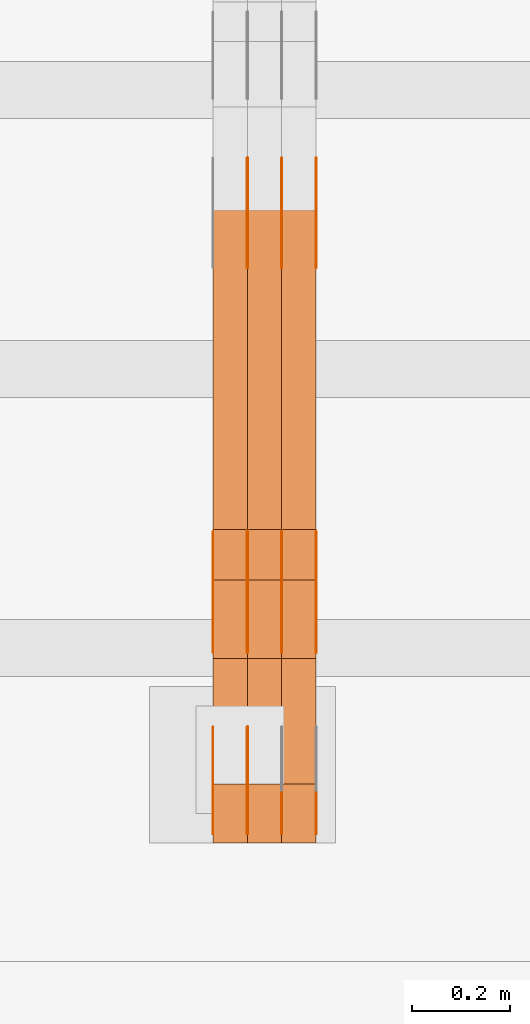
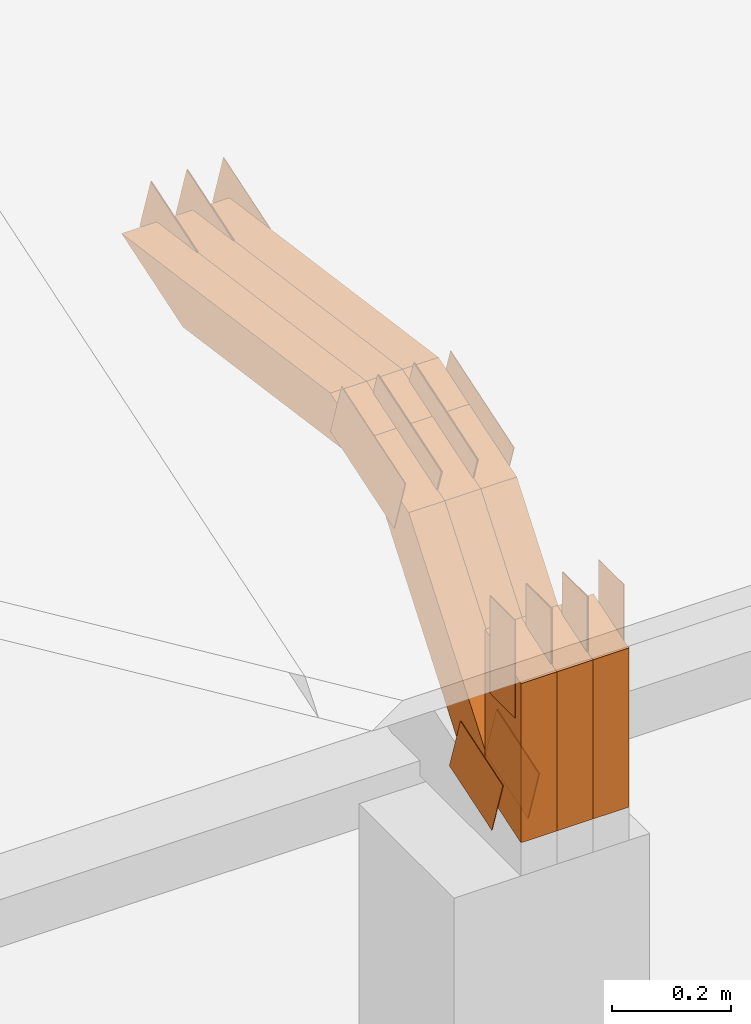
# One storey, part 248 of 385: 29 proxies.
"""IFC2X3 building model written with IfcOpenShell, lengths in millimetres."""

from ifc_helpers import new_model, entity, si_unit, converted_unit, derived_unit, direction, frame, frame_2d, origin, place, context, subcontext, project, spatial, polyline, rectangle, outline, extrude, source, transform, mapped, material, type_object, type_shapes, element, save


model = new_model("IFC2X3")

# Units and contexts
model_context = context("Model", 3, precision=0.01, world=origin(), true_north=direction((6.12303176911189e-17, 1.0)))
body_context = subcontext(model_context, "Body", "Model", "MODEL_VIEW")
ifc_project = project(units=[si_unit("LENGTHUNIT", "METRE", prefix="MILLI"), si_unit("AREAUNIT", "SQUARE_METRE"), si_unit("VOLUMEUNIT", "CUBIC_METRE"), converted_unit("PLANEANGLEUNIT", "DEGREE", entity("IfcRatioMeasure", 0.0174532925199433), si_unit("PLANEANGLEUNIT", "RADIAN"), dimensions=[0, 0, 0, 0, 0, 0, 0]), si_unit("MASSUNIT", "GRAM", prefix="KILO"), derived_unit("MASSDENSITYUNIT", [(si_unit("MASSUNIT", "GRAM", prefix="KILO"), 1), (si_unit("LENGTHUNIT", "METRE"), -3)]), si_unit("TIMEUNIT", "SECOND"), si_unit("FREQUENCYUNIT", "HERTZ"), si_unit("THERMODYNAMICTEMPERATUREUNIT", "DEGREE_CELSIUS"), derived_unit("THERMALTRANSMITTANCEUNIT", [(si_unit("MASSUNIT", "GRAM", prefix="KILO"), 1), (si_unit("THERMODYNAMICTEMPERATUREUNIT", "KELVIN"), -1), (si_unit("TIMEUNIT", "SECOND"), -3)]), derived_unit("VOLUMETRICFLOWRATEUNIT", [(si_unit("LENGTHUNIT", "METRE"), 3), (si_unit("TIMEUNIT", "SECOND"), -1)]), si_unit("ELECTRICCURRENTUNIT", "AMPERE"), si_unit("ELECTRICVOLTAGEUNIT", "VOLT"), si_unit("POWERUNIT", "WATT"), si_unit("FORCEUNIT", "NEWTON", prefix="KILO"), si_unit("ILLUMINANCEUNIT", "LUX"), si_unit("LUMINOUSFLUXUNIT", "LUMEN"), si_unit("LUMINOUSINTENSITYUNIT", "CANDELA"), derived_unit("USERDEFINED", [(si_unit("MASSUNIT", "GRAM", prefix="KILO"), -1), (si_unit("LENGTHUNIT", "METRE"), -2), (si_unit("TIMEUNIT", "SECOND"), 3), (si_unit("LUMINOUSFLUXUNIT", "LUMEN"), 1)]), derived_unit("LINEARVELOCITYUNIT", [(si_unit("LENGTHUNIT", "METRE"), 1), (si_unit("TIMEUNIT", "SECOND"), -1)]), si_unit("PRESSUREUNIT", "PASCAL"), derived_unit("USERDEFINED", [(si_unit("LENGTHUNIT", "METRE"), -2), (si_unit("MASSUNIT", "GRAM", prefix="KILO"), 1), (si_unit("TIMEUNIT", "SECOND"), -2)])], contexts=[model_context])

# Site, building, storey
site_placement = place(None, origin())
site = spatial("IfcSite", under=ifc_project, at=site_placement, CompositionType="ELEMENT")
building_placement = place(site_placement, origin())
building = spatial("IfcBuilding", under=site, at=building_placement, CompositionType="ELEMENT")
storey_placement = place(building_placement, origin())
storey = spatial("IfcBuildingStorey", under=building, at=storey_placement, Name="Default", CompositionType="ELEMENT", Elevation=0.0)

# Proxies
ifc_material_1 = material(Name="IfcSurfaceStyle #477585")
building_element_proxy_type_1 = type_object("IfcBuildingElementProxyType", PredefinedType="NOTDEFINED", material=ifc_material_1)
shared_shape_1 = source(origin(), body_context, "Body", "SweptSolid", [
    extrude(outline(polyline([(-74.999865408764, -60.0000379172698), (74.9998729365771, -60.0000379172698), (74.9998642299588, 60.0000379172698), (-74.9998717577719, 60.0000379172698), (-74.999865408764, -60.0000379172698)])), frame((75.0005044383734, 60.0001679035349, 0.0), z_axis=(0.0, 0.0, 1.0), x_axis=(-1.0, 0.0, 0.0)), (0.0, 0.0, 1.0), 1.29999999999999),
])
type_shapes(building_element_proxy_type_1, [shared_shape_1])
proxy_1_placement = place(building_placement, frame((39245.0, 2998.66143710398, 150.423871180894), z_axis=(-1.0, 0.0, 0.0), x_axis=(0.0, 0.951056516295124, 0.309016994375039)))
element("IfcBuildingElementProxy", 1, at=proxy_1_placement, inside=storey, type_object=building_element_proxy_type_1, material=ifc_material_1, context=body_context, shape_type="MappedRepresentation", body=[
    mapped(shared_shape_1, transform((0.0, 0.0, 0.0), scale=1.0)),
])
ifc_material_2 = material(Name="IfcSurfaceStyle #477528")
building_element_proxy_type_2 = type_object("IfcBuildingElementProxyType", PredefinedType="NOTDEFINED", material=ifc_material_2)
shared_shape_2 = source(origin(), body_context, "Body", "SweptSolid", [
    extrude(outline(polyline([(-74.999865408764, -60.0000379172698), (74.9998729365771, -60.0000379172698), (74.9998642299588, 60.0000379172698), (-74.9998717577719, 60.0000379172698), (-74.999865408764, -60.0000379172698)])), frame((75.0005044383734, 60.0001679035349, 0.0), z_axis=(0.0, 0.0, 1.0), x_axis=(-1.0, 0.0, 0.0)), (0.0, 0.0, 1.0), 1.29999999999999),
])
type_shapes(building_element_proxy_type_2, [shared_shape_2])
proxy_2_placement = place(building_placement, frame((39246.3, 2998.66143710398, 150.423871180894), z_axis=(-1.0, 0.0, 0.0), x_axis=(0.0, 0.951056516295124, 0.309016994375039)))
element("IfcBuildingElementProxy", 2, at=proxy_2_placement, inside=storey, type_object=building_element_proxy_type_2, material=ifc_material_2, context=body_context, shape_type="MappedRepresentation", body=[
    mapped(shared_shape_2, transform((0.0, 0.0, 0.0), scale=1.0)),
])
ifc_material_3 = material(Name="IfcSurfaceStyle #477471")
building_element_proxy_type_3 = type_object("IfcBuildingElementProxyType", PredefinedType="NOTDEFINED", material=ifc_material_3)
shared_shape_3 = source(origin(), body_context, "Body", "SweptSolid", [
    extrude(outline(polyline([(-74.999865408764, -60.0000379172698), (74.9998729365771, -60.0000379172698), (74.9998642299588, 60.0000379172698), (-74.9998717577719, 60.0000379172698), (-74.999865408764, -60.0000379172698)])), frame((75.0005044383734, 60.0001679035349, 0.0), z_axis=(0.0, 0.0, 1.0), x_axis=(-1.0, 0.0, 0.0)), (0.0, 0.0, 1.0), 1.29999999999999),
])
type_shapes(building_element_proxy_type_3, [shared_shape_3])
proxy_3_placement = place(building_placement, frame((39175.0, 2998.66143710398, 150.423871180894), z_axis=(-1.0, 0.0, 0.0), x_axis=(0.0, 0.951056516295124, 0.309016994375039)))
element("IfcBuildingElementProxy", 3, at=proxy_3_placement, inside=storey, type_object=building_element_proxy_type_3, material=ifc_material_3, context=body_context, shape_type="MappedRepresentation", body=[
    mapped(shared_shape_3, transform((0.0, 0.0, 0.0), scale=1.0)),
])
ifc_material_4 = material(Name="IfcSurfaceStyle #477414")
building_element_proxy_type_4 = type_object("IfcBuildingElementProxyType", PredefinedType="NOTDEFINED", material=ifc_material_4)
shared_shape_4 = source(origin(), body_context, "Body", "SweptSolid", [
    extrude(outline(polyline([(-99.9998204243802, -60.000067376167), (99.9998338462265, -60.000067376167), (99.9998204243802, 60.000067376167), (-99.9998338462265, 60.000067376167), (-99.9998204243802, -60.000067376167)])), frame((100.000602015329, 60.0001864986889, 0.0), z_axis=(0.0, 0.0, 1.0), x_axis=(-1.0, 0.0, 0.0)), (0.0, 0.0, 1.0), 1.3),
])
type_shapes(building_element_proxy_type_4, [shared_shape_4])
proxy_4_placement = place(building_placement, frame((39386.3, 4114.85465165112, 513.097031388771), z_axis=(-1.0, 0.0, 0.0), x_axis=(0.0, 0.951056516295124, 0.309016994375039)))
element("IfcBuildingElementProxy", 4, at=proxy_4_placement, inside=storey, type_object=building_element_proxy_type_4, material=ifc_material_4, context=body_context, shape_type="MappedRepresentation", body=[
    mapped(shared_shape_4, transform((0.0, 0.0, 0.0), scale=1.0)),
])
ifc_material_5 = material(Name="IfcSurfaceStyle #477357")
building_element_proxy_type_5 = type_object("IfcBuildingElementProxyType", PredefinedType="NOTDEFINED", material=ifc_material_5)
shared_shape_5 = source(origin(), body_context, "Body", "SweptSolid", [
    extrude(outline(polyline([(-99.9998204243802, -60.000067376167), (99.9998338462265, -60.000067376167), (99.9998204243802, 60.000067376167), (-99.9998338462265, 60.000067376167), (-99.9998204243802, -60.000067376167)])), frame((100.000602015329, 60.0001864986889, 0.0), z_axis=(0.0, 0.0, 1.0), x_axis=(-1.0, 0.0, 0.0)), (0.0, 0.0, 1.0), 1.3),
])
type_shapes(building_element_proxy_type_5, [shared_shape_5])
proxy_5_placement = place(building_placement, frame((39315.0, 4114.85465165112, 513.097031388771), z_axis=(-1.0, 0.0, 0.0), x_axis=(0.0, 0.951056516295124, 0.309016994375039)))
element("IfcBuildingElementProxy", 5, at=proxy_5_placement, inside=storey, type_object=building_element_proxy_type_5, material=ifc_material_5, context=body_context, shape_type="MappedRepresentation", body=[
    mapped(shared_shape_5, transform((0.0, 0.0, 0.0), scale=1.0)),
])
ifc_material_6 = material(Name="IfcSurfaceStyle #477300")
building_element_proxy_type_6 = type_object("IfcBuildingElementProxyType", PredefinedType="NOTDEFINED", material=ifc_material_6)
shared_shape_6 = source(origin(), body_context, "Body", "SweptSolid", [
    extrude(outline(polyline([(-99.9998204243802, -60.000067376167), (99.9998338462265, -60.000067376167), (99.9998204243802, 60.000067376167), (-99.9998338462265, 60.000067376167), (-99.9998204243802, -60.000067376167)])), frame((100.000602015329, 60.0001864986889, 0.0), z_axis=(0.0, 0.0, 1.0), x_axis=(-1.0, 0.0, 0.0)), (0.0, 0.0, 1.0), 1.3),
])
type_shapes(building_element_proxy_type_6, [shared_shape_6])
proxy_6_placement = place(building_placement, frame((39316.3, 4114.85465165112, 513.097031388771), z_axis=(-1.0, 0.0, 0.0), x_axis=(0.0, 0.951056516295124, 0.309016994375039)))
element("IfcBuildingElementProxy", 6, at=proxy_6_placement, inside=storey, type_object=building_element_proxy_type_6, material=ifc_material_6, context=body_context, shape_type="MappedRepresentation", body=[
    mapped(shared_shape_6, transform((0.0, 0.0, 0.0), scale=1.0)),
])
ifc_material_7 = material(Name="IfcSurfaceStyle #477243")
building_element_proxy_type_7 = type_object("IfcBuildingElementProxyType", PredefinedType="NOTDEFINED", material=ifc_material_7)
shared_shape_7 = source(origin(), body_context, "Body", "SweptSolid", [
    extrude(outline(polyline([(-99.9998204243802, -60.000067376167), (99.9998338462265, -60.000067376167), (99.9998204243802, 60.000067376167), (-99.9998338462265, 60.000067376167), (-99.9998204243802, -60.000067376167)])), frame((100.000602015329, 60.0001864986889, 0.0), z_axis=(0.0, 0.0, 1.0), x_axis=(-1.0, 0.0, 0.0)), (0.0, 0.0, 1.0), 1.29999999999998),
])
type_shapes(building_element_proxy_type_7, [shared_shape_7])
proxy_7_placement = place(building_placement, frame((39245.0, 4114.85465165112, 513.097031388771), z_axis=(-1.0, 0.0, 0.0), x_axis=(0.0, 0.951056516295124, 0.309016994375039)))
element("IfcBuildingElementProxy", 7, at=proxy_7_placement, inside=storey, type_object=building_element_proxy_type_7, material=ifc_material_7, context=body_context, shape_type="MappedRepresentation", body=[
    mapped(shared_shape_7, transform((0.0, 0.0, 0.0), scale=1.0)),
])
ifc_material_8 = material(Name="IfcSurfaceStyle #477186")
building_element_proxy_type_8 = type_object("IfcBuildingElementProxyType", PredefinedType="NOTDEFINED", material=ifc_material_8)
shared_shape_8 = source(origin(), body_context, "Body", "SweptSolid", [
    extrude(outline(polyline([(-99.9998204243802, -60.000067376167), (99.9998338462265, -60.000067376167), (99.9998204243802, 60.000067376167), (-99.9998338462265, 60.000067376167), (-99.9998204243802, -60.000067376167)])), frame((100.000602015329, 60.0001864986889, 0.0), z_axis=(0.0, 0.0, 1.0), x_axis=(-1.0, 0.0, 0.0)), (0.0, 0.0, 1.0), 1.29999999999998),
])
type_shapes(building_element_proxy_type_8, [shared_shape_8])
proxy_8_placement = place(building_placement, frame((39246.3, 4114.85465165112, 513.097031388771), z_axis=(-1.0, 0.0, 0.0), x_axis=(0.0, 0.951056516295124, 0.309016994375039)))
element("IfcBuildingElementProxy", 8, at=proxy_8_placement, inside=storey, type_object=building_element_proxy_type_8, material=ifc_material_8, context=body_context, shape_type="MappedRepresentation", body=[
    mapped(shared_shape_8, transform((0.0, 0.0, 0.0), scale=1.0)),
])
ifc_material_9 = material(Name="IfcSurfaceStyle #469206")
building_element_proxy_type_9 = type_object("IfcBuildingElementProxyType", PredefinedType="NOTDEFINED", material=ifc_material_9)
shared_shape_9 = source(origin(), body_context, "Body", "SweptSolid", [
    extrude(outline(polyline([(-112.500266735783, -59.9999130784581), (112.500275442392, -59.9999130784581), (112.500262020557, 59.9999130784582), (-112.500270727166, 59.9999130784581), (-112.500266735783, -59.9999130784581)])), frame((112.500275442392, 60.0001020984692, 0.0), z_axis=(0.0, 0.0, 1.0), x_axis=(-1.0, 0.0, 0.0)), (0.0, 0.0, 1.0), 1.3),
])
type_shapes(building_element_proxy_type_9, [shared_shape_9])
proxy_9_placement = place(building_placement, frame((39386.3, 3327.32420598508, 571.284602786019), z_axis=(-1.0, 0.0, 0.0), x_axis=(0.0, 0.951056516295154, 0.309016994374948)))
element("IfcBuildingElementProxy", 9, at=proxy_9_placement, inside=storey, type_object=building_element_proxy_type_9, material=ifc_material_9, context=body_context, shape_type="MappedRepresentation", body=[
    mapped(shared_shape_9, transform((0.0, 0.0, 0.0), scale=1.0)),
])
ifc_material_10 = material(Name="IfcSurfaceStyle #469149")
building_element_proxy_type_10 = type_object("IfcBuildingElementProxyType", PredefinedType="NOTDEFINED", material=ifc_material_10)
shared_shape_10 = source(origin(), body_context, "Body", "SweptSolid", [
    extrude(outline(polyline([(-112.500266735783, -59.9999130784581), (112.500275442392, -59.9999130784581), (112.500262020557, 59.9999130784582), (-112.500270727166, 59.9999130784581), (-112.500266735783, -59.9999130784581)])), frame((112.500275442392, 60.0001020984692, 0.0), z_axis=(0.0, 0.0, 1.0), x_axis=(-1.0, 0.0, 0.0)), (0.0, 0.0, 1.0), 1.3),
])
type_shapes(building_element_proxy_type_10, [shared_shape_10])
proxy_10_placement = place(building_placement, frame((39315.0, 3327.32420598508, 571.284602786019), z_axis=(-1.0, 0.0, 0.0), x_axis=(0.0, 0.951056516295154, 0.309016994374948)))
element("IfcBuildingElementProxy", 10, at=proxy_10_placement, inside=storey, type_object=building_element_proxy_type_10, material=ifc_material_10, context=body_context, shape_type="MappedRepresentation", body=[
    mapped(shared_shape_10, transform((0.0, 0.0, 0.0), scale=1.0)),
])
ifc_material_11 = material(Name="IfcSurfaceStyle #469092")
building_element_proxy_type_11 = type_object("IfcBuildingElementProxyType", PredefinedType="NOTDEFINED", material=ifc_material_11)
shared_shape_11 = source(origin(), body_context, "Body", "SweptSolid", [
    extrude(outline(polyline([(-112.500266735783, -59.9999130784581), (112.500275442392, -59.9999130784581), (112.500262020557, 59.9999130784582), (-112.500270727166, 59.9999130784581), (-112.500266735783, -59.9999130784581)])), frame((112.500275442392, 60.0001020984692, 0.0), z_axis=(0.0, 0.0, 1.0), x_axis=(-1.0, 0.0, 0.0)), (0.0, 0.0, 1.0), 1.3),
])
type_shapes(building_element_proxy_type_11, [shared_shape_11])
proxy_11_placement = place(building_placement, frame((39316.3, 3327.32420598508, 571.284602786019), z_axis=(-1.0, 0.0, 0.0), x_axis=(0.0, 0.951056516295154, 0.309016994374948)))
element("IfcBuildingElementProxy", 11, at=proxy_11_placement, inside=storey, type_object=building_element_proxy_type_11, material=ifc_material_11, context=body_context, shape_type="MappedRepresentation", body=[
    mapped(shared_shape_11, transform((0.0, 0.0, 0.0), scale=1.0)),
])
ifc_material_12 = material(Name="IfcSurfaceStyle #469035")
building_element_proxy_type_12 = type_object("IfcBuildingElementProxyType", PredefinedType="NOTDEFINED", material=ifc_material_12)
shared_shape_12 = source(origin(), body_context, "Body", "SweptSolid", [
    extrude(outline(polyline([(-112.500266735783, -59.9999130784581), (112.500275442392, -59.9999130784581), (112.500262020557, 59.9999130784582), (-112.500270727166, 59.9999130784581), (-112.500266735783, -59.9999130784581)])), frame((112.500275442392, 60.0001020984692, 0.0), z_axis=(0.0, 0.0, 1.0), x_axis=(-1.0, 0.0, 0.0)), (0.0, 0.0, 1.0), 1.29999999999998),
])
type_shapes(building_element_proxy_type_12, [shared_shape_12])
proxy_12_placement = place(building_placement, frame((39245.0, 3327.32420598508, 571.284602786019), z_axis=(-1.0, 0.0, 0.0), x_axis=(0.0, 0.951056516295154, 0.309016994374948)))
element("IfcBuildingElementProxy", 12, at=proxy_12_placement, inside=storey, type_object=building_element_proxy_type_12, material=ifc_material_12, context=body_context, shape_type="MappedRepresentation", body=[
    mapped(shared_shape_12, transform((0.0, 0.0, 0.0), scale=1.0)),
])
ifc_material_13 = material(Name="IfcSurfaceStyle #468978")
building_element_proxy_type_13 = type_object("IfcBuildingElementProxyType", PredefinedType="NOTDEFINED", material=ifc_material_13)
shared_shape_13 = source(origin(), body_context, "Body", "SweptSolid", [
    extrude(outline(polyline([(-112.500266735783, -59.9999130784581), (112.500275442392, -59.9999130784581), (112.500262020557, 59.9999130784582), (-112.500270727166, 59.9999130784581), (-112.500266735783, -59.9999130784581)])), frame((112.500275442392, 60.0001020984692, 0.0), z_axis=(0.0, 0.0, 1.0), x_axis=(-1.0, 0.0, 0.0)), (0.0, 0.0, 1.0), 1.29999999999998),
])
type_shapes(building_element_proxy_type_13, [shared_shape_13])
proxy_13_placement = place(building_placement, frame((39246.3, 3327.32420598508, 571.284602786019), z_axis=(-1.0, 0.0, 0.0), x_axis=(0.0, 0.951056516295154, 0.309016994374948)))
element("IfcBuildingElementProxy", 13, at=proxy_13_placement, inside=storey, type_object=building_element_proxy_type_13, material=ifc_material_13, context=body_context, shape_type="MappedRepresentation", body=[
    mapped(shared_shape_13, transform((0.0, 0.0, 0.0), scale=1.0)),
])
ifc_material_14 = material(Name="IfcSurfaceStyle #468921")
building_element_proxy_type_14 = type_object("IfcBuildingElementProxyType", PredefinedType="NOTDEFINED", material=ifc_material_14)
shared_shape_14 = source(origin(), body_context, "Body", "SweptSolid", [
    extrude(outline(polyline([(-112.500266735783, -59.9999130784581), (112.500275442392, -59.9999130784581), (112.500262020557, 59.9999130784582), (-112.500270727166, 59.9999130784581), (-112.500266735783, -59.9999130784581)])), frame((112.500275442392, 60.0001020984692, 0.0), z_axis=(0.0, 0.0, 1.0), x_axis=(-1.0, 0.0, 0.0)), (0.0, 0.0, 1.0), 1.29999999999999),
])
type_shapes(building_element_proxy_type_14, [shared_shape_14])
proxy_14_placement = place(building_placement, frame((39175.0, 3327.32420598508, 571.284602786019), z_axis=(-1.0, 0.0, 0.0), x_axis=(0.0, 0.951056516295154, 0.309016994374948)))
element("IfcBuildingElementProxy", 14, at=proxy_14_placement, inside=storey, type_object=building_element_proxy_type_14, material=ifc_material_14, context=body_context, shape_type="MappedRepresentation", body=[
    mapped(shared_shape_14, transform((0.0, 0.0, 0.0), scale=1.0)),
])
ifc_material_15 = material(Name="IfcSurfaceStyle #468180")
building_element_proxy_type_15 = type_object("IfcBuildingElementProxyType", PredefinedType="NOTDEFINED", material=ifc_material_15)
shared_shape_15 = source(origin(), body_context, "Body", "SweptSolid", [
    extrude(rectangle(XDim=199.999969482422, YDim=84.0, at=frame_2d((1.4210854715202e-14, 0.0), x_axis=(1.0, 0.0))), frame((100.000010815955, 42.0, 0.0), z_axis=(0.0, 0.0, 1.0), x_axis=(-1.0, 0.0, 0.0)), (0.0, 0.0, 1.0), 1.3),
])
type_shapes(building_element_proxy_type_15, [shared_shape_15])
proxy_15_placement = place(building_placement, frame((39386.3, 3042.0, 514.460048047401), z_axis=(-1.0, 0.0, 0.0), x_axis=(0.0, 0.0, -1.0)))
element("IfcBuildingElementProxy", 15, at=proxy_15_placement, inside=storey, type_object=building_element_proxy_type_15, material=ifc_material_15, context=body_context, shape_type="MappedRepresentation", body=[
    mapped(shared_shape_15, transform((0.0, 0.0, 0.0), scale=1.0)),
])
ifc_material_16 = material(Name="IfcSurfaceStyle #468123")
building_element_proxy_type_16 = type_object("IfcBuildingElementProxyType", PredefinedType="NOTDEFINED", material=ifc_material_16)
shared_shape_16 = source(origin(), body_context, "Body", "SweptSolid", [
    extrude(rectangle(XDim=199.999969482422, YDim=84.0, at=frame_2d((1.4210854715202e-14, 0.0), x_axis=(1.0, 0.0))), frame((100.000010815955, 42.0, 0.0), z_axis=(0.0, 0.0, 1.0), x_axis=(-1.0, 0.0, 0.0)), (0.0, 0.0, 1.0), 1.3),
])
type_shapes(building_element_proxy_type_16, [shared_shape_16])
proxy_16_placement = place(building_placement, frame((39315.0, 3042.0, 514.460048047401), z_axis=(-1.0, 0.0, 0.0), x_axis=(0.0, 0.0, -1.0)))
element("IfcBuildingElementProxy", 16, at=proxy_16_placement, inside=storey, type_object=building_element_proxy_type_16, material=ifc_material_16, context=body_context, shape_type="MappedRepresentation", body=[
    mapped(shared_shape_16, transform((0.0, 0.0, 0.0), scale=1.0)),
])
ifc_material_17 = material(Name="IfcSurfaceStyle #468066")
building_element_proxy_type_17 = type_object("IfcBuildingElementProxyType", PredefinedType="NOTDEFINED", material=ifc_material_17)
shared_shape_17 = source(origin(), body_context, "Body", "SweptSolid", [
    extrude(rectangle(XDim=199.999969482422, YDim=84.0, at=frame_2d((1.4210854715202e-14, 0.0), x_axis=(1.0, 0.0))), frame((100.000010815955, 42.0, 0.0), z_axis=(0.0, 0.0, 1.0), x_axis=(-1.0, 0.0, 0.0)), (0.0, 0.0, 1.0), 1.3),
])
type_shapes(building_element_proxy_type_17, [shared_shape_17])
proxy_17_placement = place(building_placement, frame((39316.3, 3042.0, 514.460048047401), z_axis=(-1.0, 0.0, 0.0), x_axis=(0.0, 0.0, -1.0)))
element("IfcBuildingElementProxy", 17, at=proxy_17_placement, inside=storey, type_object=building_element_proxy_type_17, material=ifc_material_17, context=body_context, shape_type="MappedRepresentation", body=[
    mapped(shared_shape_17, transform((0.0, 0.0, 0.0), scale=1.0)),
])
ifc_material_18 = material(Name="IfcSurfaceStyle #468009")
building_element_proxy_type_18 = type_object("IfcBuildingElementProxyType", PredefinedType="NOTDEFINED", material=ifc_material_18)
shared_shape_18 = source(origin(), body_context, "Body", "SweptSolid", [
    extrude(rectangle(XDim=199.999969482422, YDim=84.0, at=frame_2d((1.4210854715202e-14, 0.0), x_axis=(1.0, 0.0))), frame((100.000010815955, 42.0, 0.0), z_axis=(0.0, 0.0, 1.0), x_axis=(-1.0, 0.0, 0.0)), (0.0, 0.0, 1.0), 1.29999999999998),
])
type_shapes(building_element_proxy_type_18, [shared_shape_18])
proxy_18_placement = place(building_placement, frame((39245.0, 3042.0, 514.460048047401), z_axis=(-1.0, 0.0, 0.0), x_axis=(0.0, 0.0, -1.0)))
element("IfcBuildingElementProxy", 18, at=proxy_18_placement, inside=storey, type_object=building_element_proxy_type_18, material=ifc_material_18, context=body_context, shape_type="MappedRepresentation", body=[
    mapped(shared_shape_18, transform((0.0, 0.0, 0.0), scale=1.0)),
])
ifc_material_19 = material(Name="IfcSurfaceStyle #467952")
building_element_proxy_type_19 = type_object("IfcBuildingElementProxyType", PredefinedType="NOTDEFINED", material=ifc_material_19)
shared_shape_19 = source(origin(), body_context, "Body", "SweptSolid", [
    extrude(rectangle(XDim=199.999969482422, YDim=84.0, at=frame_2d((1.4210854715202e-14, 0.0), x_axis=(1.0, 0.0))), frame((100.000010815955, 42.0, 0.0), z_axis=(0.0, 0.0, 1.0), x_axis=(-1.0, 0.0, 0.0)), (0.0, 0.0, 1.0), 1.29999999999998),
])
type_shapes(building_element_proxy_type_19, [shared_shape_19])
proxy_19_placement = place(building_placement, frame((39246.3, 3042.0, 514.460048047401), z_axis=(-1.0, 0.0, 0.0), x_axis=(0.0, 0.0, -1.0)))
element("IfcBuildingElementProxy", 19, at=proxy_19_placement, inside=storey, type_object=building_element_proxy_type_19, material=ifc_material_19, context=body_context, shape_type="MappedRepresentation", body=[
    mapped(shared_shape_19, transform((0.0, 0.0, 0.0), scale=1.0)),
])
ifc_material_20 = material(Name="IfcSurfaceStyle #467895")
building_element_proxy_type_20 = type_object("IfcBuildingElementProxyType", PredefinedType="NOTDEFINED", material=ifc_material_20)
shared_shape_20 = source(origin(), body_context, "Body", "SweptSolid", [
    extrude(rectangle(XDim=199.999969482422, YDim=84.0, at=frame_2d((1.4210854715202e-14, 0.0), x_axis=(1.0, 0.0))), frame((100.000010815955, 42.0, 0.0), z_axis=(0.0, 0.0, 1.0), x_axis=(-1.0, 0.0, 0.0)), (0.0, 0.0, 1.0), 1.29999999999999),
])
type_shapes(building_element_proxy_type_20, [shared_shape_20])
proxy_20_placement = place(building_placement, frame((39175.0, 3042.0, 514.460048047401), z_axis=(-1.0, 0.0, 0.0), x_axis=(0.0, 0.0, -1.0)))
element("IfcBuildingElementProxy", 20, at=proxy_20_placement, inside=storey, type_object=building_element_proxy_type_20, material=ifc_material_20, context=body_context, shape_type="MappedRepresentation", body=[
    mapped(shared_shape_20, transform((0.0, 0.0, 0.0), scale=1.0)),
])
ifc_material_21 = material(Name="IfcSurfaceStyle #456912")
building_element_proxy_type_21 = type_object("IfcBuildingElementProxyType", Name="T1-W3 456910", PredefinedType="NOTDEFINED", material=ifc_material_21)
shared_shape_21 = source(origin(), body_context, "Body", "SweptSolid", [
    extrude(outline(polyline([(-314.232579911788, -47.5000200125938), (325.164873061766, -47.5000200125938), (297.999869081008, 6.48085173424295e-05), (200.434027234171, 47.4999876083351), (-509.366189465157, 47.4999876083352), (-314.232579911788, -47.5000200125938)])), frame((325.164873061766, 47.5001564752191, 0.0), z_axis=(0.0, 0.0, 1.0), x_axis=(-1.0, 0.0, 0.0)), (0.0, 0.0, 1.0), 70.0),
])
type_shapes(building_element_proxy_type_21, [shared_shape_21])
proxy_21_placement = place(building_placement, frame((39385.0, 3457.43747924876, 620.49890325051), z_axis=(-1.0, 0.0, 0.0), x_axis=(0.0, 0.990367219823621, -0.138465771578512)))
element("IfcBuildingElementProxy", 21, at=proxy_21_placement, inside=storey, type_object=building_element_proxy_type_21, material=ifc_material_21, Name="T1-W3", context=body_context, shape_type="MappedRepresentation", body=[
    mapped(shared_shape_21, transform((0.0, 0.0, 0.0), scale=1.0)),
])
ifc_material_22 = material(Name="IfcSurfaceStyle #456846")
building_element_proxy_type_22 = type_object("IfcBuildingElementProxyType", Name="T1-W3 456844", PredefinedType="NOTDEFINED", material=ifc_material_22)
shared_shape_22 = source(origin(), body_context, "Body", "SweptSolid", [
    extrude(outline(polyline([(-314.232579911788, -47.5000200125938), (325.164873061766, -47.5000200125938), (297.999869081008, 6.48085173424295e-05), (200.434027234171, 47.4999876083351), (-509.366189465157, 47.4999876083352), (-314.232579911788, -47.5000200125938)])), frame((325.164873061766, 47.5001564752191, 0.0), z_axis=(0.0, 0.0, 1.0), x_axis=(-1.0, 0.0, 0.0)), (0.0, 0.0, 1.0), 70.0),
])
type_shapes(building_element_proxy_type_22, [shared_shape_22])
proxy_22_placement = place(building_placement, frame((39315.0, 3457.43747924876, 620.49890325051), z_axis=(-1.0, 0.0, 0.0), x_axis=(0.0, 0.990367219823621, -0.138465771578512)))
element("IfcBuildingElementProxy", 22, at=proxy_22_placement, inside=storey, type_object=building_element_proxy_type_22, material=ifc_material_22, Name="T1-W3", context=body_context, shape_type="MappedRepresentation", body=[
    mapped(shared_shape_22, transform((0.0, 0.0, 0.0), scale=1.0)),
])
ifc_material_23 = material(Name="IfcSurfaceStyle #456780")
building_element_proxy_type_23 = type_object("IfcBuildingElementProxyType", Name="T1-W3 456778", PredefinedType="NOTDEFINED", material=ifc_material_23)
shared_shape_23 = source(origin(), body_context, "Body", "SweptSolid", [
    extrude(outline(polyline([(-314.232579911788, -47.5000200125938), (325.164873061766, -47.5000200125938), (297.999869081008, 6.48085173424295e-05), (200.434027234171, 47.4999876083351), (-509.366189465157, 47.4999876083352), (-314.232579911788, -47.5000200125938)])), frame((325.164873061766, 47.5001564752191, 0.0), z_axis=(0.0, 0.0, 1.0), x_axis=(-1.0, 0.0, 0.0)), (0.0, 0.0, 1.0), 70.0),
])
type_shapes(building_element_proxy_type_23, [shared_shape_23])
proxy_23_placement = place(building_placement, frame((39245.0, 3457.43747924876, 620.49890325051), z_axis=(-1.0, 0.0, 0.0), x_axis=(0.0, 0.990367219823621, -0.138465771578512)))
element("IfcBuildingElementProxy", 23, at=proxy_23_placement, inside=storey, type_object=building_element_proxy_type_23, material=ifc_material_23, Name="T1-W3", context=body_context, shape_type="MappedRepresentation", body=[
    mapped(shared_shape_23, transform((0.0, 0.0, 0.0), scale=1.0)),
])
ifc_material_24 = material(Name="IfcSurfaceStyle #456516")
building_element_proxy_type_24 = type_object("IfcBuildingElementProxyType", Name="T1-W14 456514", PredefinedType="NOTDEFINED", material=ifc_material_24)
shared_shape_24 = source(origin(), body_context, "Body", "SweptSolid", [
    extrude(outline(polyline([(-374.484689776928, -47.499919737532), (177.199556189275, -47.499919737532), (246.893257937645, -5.36774925340877e-05), (185.487930694801, 47.4999465762783), (-235.096055044793, 47.4999465762784), (-374.484689776928, -47.499919737532)])), frame((246.893257937645, 47.5000959779252, 0.0), z_axis=(0.0, 0.0, 1.0), x_axis=(-1.0, 0.0, 0.0)), (0.0, 0.0, 1.0), 70.0),
])
type_shapes(building_element_proxy_type_24, [shared_shape_24])
proxy_24_placement = place(building_placement, frame((39385.0, 3022.42877773025, 136.329406512195), z_axis=(-1.0, 0.0, 0.0), x_axis=(0.0, 0.611854146609475, 0.790970608352037)))
element("IfcBuildingElementProxy", 24, at=proxy_24_placement, inside=storey, type_object=building_element_proxy_type_24, material=ifc_material_24, Name="T1-W14", context=body_context, shape_type="MappedRepresentation", body=[
    mapped(shared_shape_24, transform((0.0, 0.0, 0.0), scale=1.0)),
])
ifc_material_25 = material(Name="IfcSurfaceStyle #456450")
building_element_proxy_type_25 = type_object("IfcBuildingElementProxyType", Name="T1-W14 456448", PredefinedType="NOTDEFINED", material=ifc_material_25)
shared_shape_25 = source(origin(), body_context, "Body", "SweptSolid", [
    extrude(outline(polyline([(-374.484689776928, -47.499919737532), (177.199556189275, -47.499919737532), (246.893257937645, -5.36774925340877e-05), (185.487930694801, 47.4999465762783), (-235.096055044793, 47.4999465762784), (-374.484689776928, -47.499919737532)])), frame((246.893257937645, 47.5000959779252, 0.0), z_axis=(0.0, 0.0, 1.0), x_axis=(-1.0, 0.0, 0.0)), (0.0, 0.0, 1.0), 70.0),
])
type_shapes(building_element_proxy_type_25, [shared_shape_25])
proxy_25_placement = place(building_placement, frame((39315.0, 3022.42877773025, 136.329406512195), z_axis=(-1.0, 0.0, 0.0), x_axis=(0.0, 0.611854146609475, 0.790970608352037)))
element("IfcBuildingElementProxy", 25, at=proxy_25_placement, inside=storey, type_object=building_element_proxy_type_25, material=ifc_material_25, Name="T1-W14", context=body_context, shape_type="MappedRepresentation", body=[
    mapped(shared_shape_25, transform((0.0, 0.0, 0.0), scale=1.0)),
])
ifc_material_26 = material(Name="IfcSurfaceStyle #456384")
building_element_proxy_type_26 = type_object("IfcBuildingElementProxyType", Name="T1-W14 456382", PredefinedType="NOTDEFINED", material=ifc_material_26)
shared_shape_26 = source(origin(), body_context, "Body", "SweptSolid", [
    extrude(outline(polyline([(-374.484689776928, -47.499919737532), (177.199556189275, -47.499919737532), (246.893257937645, -5.36774925340877e-05), (185.487930694801, 47.4999465762783), (-235.096055044793, 47.4999465762784), (-374.484689776928, -47.499919737532)])), frame((246.893257937645, 47.5000959779252, 0.0), z_axis=(0.0, 0.0, 1.0), x_axis=(-1.0, 0.0, 0.0)), (0.0, 0.0, 1.0), 70.0),
])
type_shapes(building_element_proxy_type_26, [shared_shape_26])
proxy_26_placement = place(building_placement, frame((39245.0, 3022.42877773025, 136.329406512195), z_axis=(-1.0, 0.0, 0.0), x_axis=(0.0, 0.611854146609475, 0.790970608352037)))
element("IfcBuildingElementProxy", 26, at=proxy_26_placement, inside=storey, type_object=building_element_proxy_type_26, material=ifc_material_26, Name="T1-W14", context=body_context, shape_type="MappedRepresentation", body=[
    mapped(shared_shape_26, transform((0.0, 0.0, 0.0), scale=1.0)),
])
ifc_material_27 = material(Name="IfcSurfaceStyle #456318")
building_element_proxy_type_27 = type_object("IfcBuildingElementProxyType", Name="T1-E3 456316", PredefinedType="NOTDEFINED", material=ifc_material_27)
shared_shape_27 = source(origin(), body_context, "Body", "SweptSolid", [
    extrude(outline(polyline([(-182.839673995971, -60.0), (143.849313735962, -60.0), (182.839677810669, 60.0), (-143.84931755066, 60.0), (-182.839673995971, -60.0)])), frame((182.839677810669, 60.0, 0.0), z_axis=(0.0, 0.0, 1.0), x_axis=(-1.0, 0.0, 0.0)), (0.0, 0.0, 1.0), 70.0),
])
type_shapes(building_element_proxy_type_27, [shared_shape_27])
proxy_27_placement = place(building_placement, frame((39385.0, 2940.0, 68.27587890625), z_axis=(-1.0, 0.0, 0.0), x_axis=(0.0, 0.0, 1.0)))
element("IfcBuildingElementProxy", 27, at=proxy_27_placement, inside=storey, type_object=building_element_proxy_type_27, material=ifc_material_27, Name="T1-E3", context=body_context, shape_type="MappedRepresentation", body=[
    mapped(shared_shape_27, transform((0.0, 0.0, 0.0), scale=1.0)),
])
ifc_material_28 = material(Name="IfcSurfaceStyle #456261")
building_element_proxy_type_28 = type_object("IfcBuildingElementProxyType", Name="T1-E3 456259", PredefinedType="NOTDEFINED", material=ifc_material_28)
shared_shape_28 = source(origin(), body_context, "Body", "SweptSolid", [
    extrude(outline(polyline([(-182.839673995971, -60.0), (143.849313735962, -60.0), (182.839677810669, 60.0), (-143.84931755066, 60.0), (-182.839673995971, -60.0)])), frame((182.839677810669, 60.0, 0.0), z_axis=(0.0, 0.0, 1.0), x_axis=(-1.0, 0.0, 0.0)), (0.0, 0.0, 1.0), 70.0),
])
type_shapes(building_element_proxy_type_28, [shared_shape_28])
proxy_28_placement = place(building_placement, frame((39315.0, 2940.0, 68.27587890625), z_axis=(-1.0, 0.0, 0.0), x_axis=(0.0, 0.0, 1.0)))
element("IfcBuildingElementProxy", 28, at=proxy_28_placement, inside=storey, type_object=building_element_proxy_type_28, material=ifc_material_28, Name="T1-E3", context=body_context, shape_type="MappedRepresentation", body=[
    mapped(shared_shape_28, transform((0.0, 0.0, 0.0), scale=1.0)),
])
ifc_material_29 = material(Name="IfcSurfaceStyle #456204")
building_element_proxy_type_29 = type_object("IfcBuildingElementProxyType", Name="T1-E3 456202", PredefinedType="NOTDEFINED", material=ifc_material_29)
shared_shape_29 = source(origin(), body_context, "Body", "SweptSolid", [
    extrude(outline(polyline([(-182.839673995971, -60.0), (143.849313735962, -60.0), (182.839677810669, 60.0), (-143.84931755066, 60.0), (-182.839673995971, -60.0)])), frame((182.839677810669, 60.0, 0.0), z_axis=(0.0, 0.0, 1.0), x_axis=(-1.0, 0.0, 0.0)), (0.0, 0.0, 1.0), 70.0),
])
type_shapes(building_element_proxy_type_29, [shared_shape_29])
proxy_29_placement = place(building_placement, frame((39245.0, 2940.0, 68.27587890625), z_axis=(-1.0, 0.0, 0.0), x_axis=(0.0, 0.0, 1.0)))
element("IfcBuildingElementProxy", 29, at=proxy_29_placement, inside=storey, type_object=building_element_proxy_type_29, material=ifc_material_29, Name="T1-E3", context=body_context, shape_type="MappedRepresentation", body=[
    mapped(shared_shape_29, transform((0.0, 0.0, 0.0), scale=1.0)),
])

save(model, "model.ifc")
